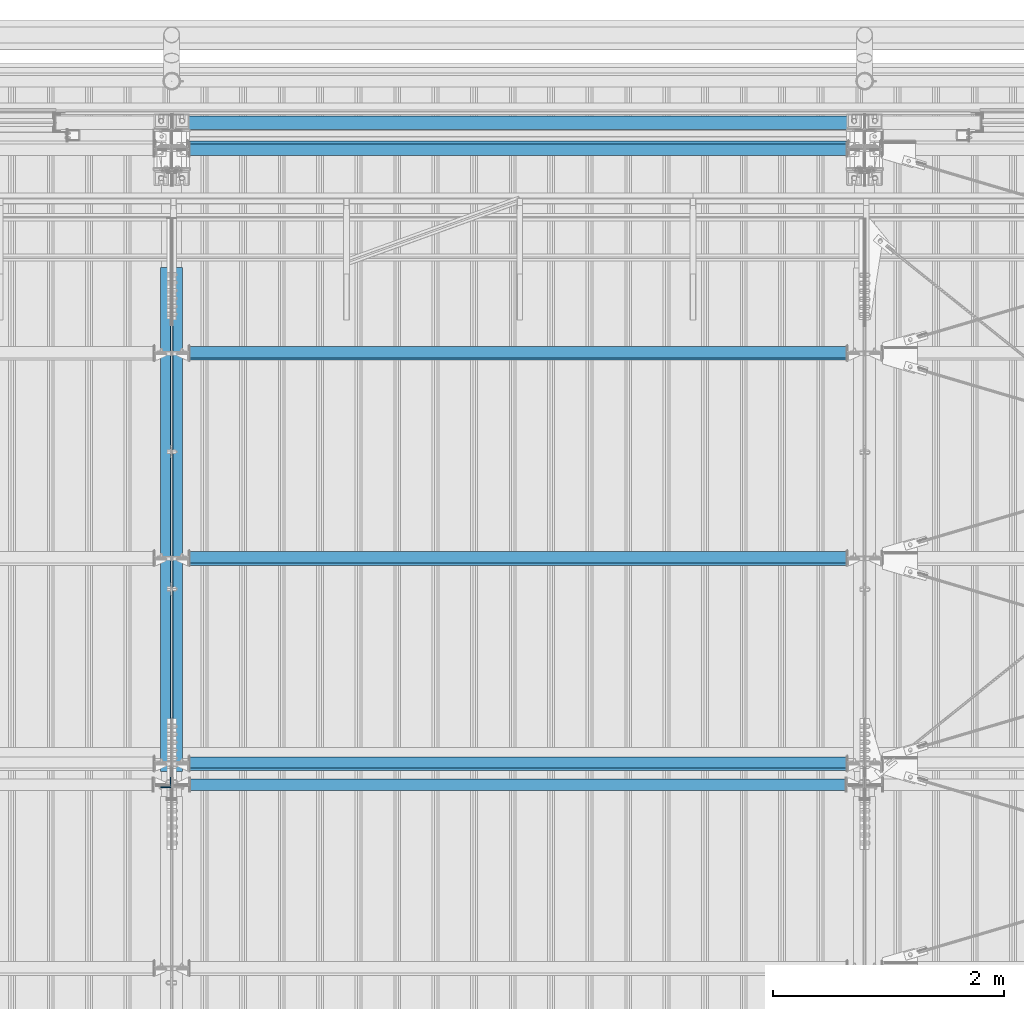
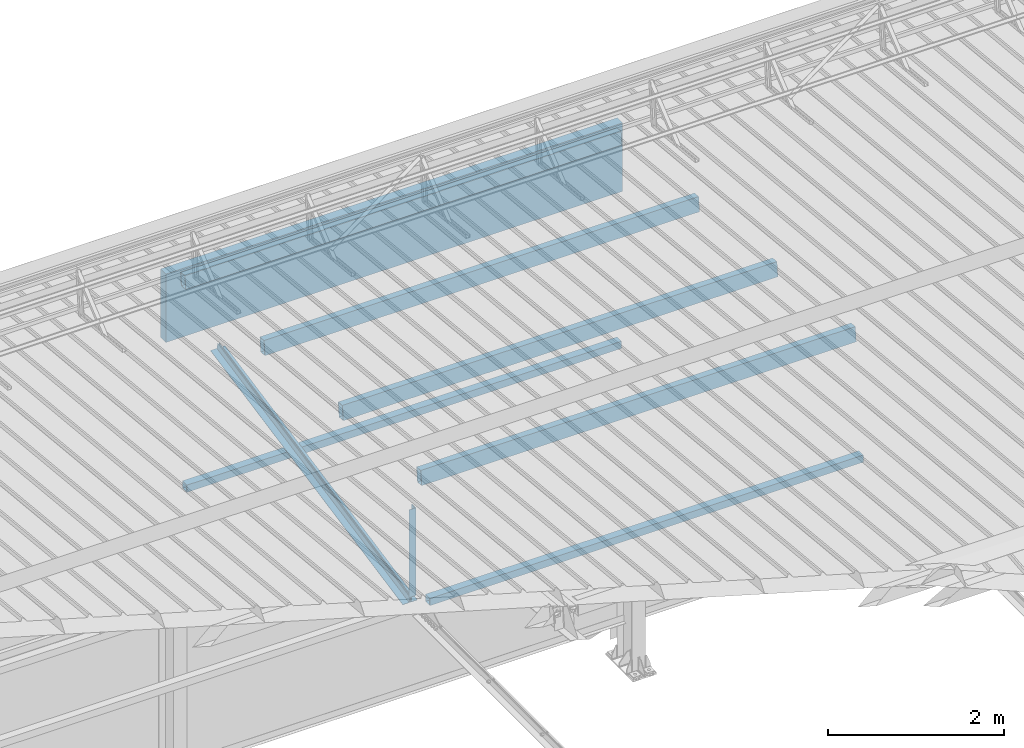
# One storey, part 285 of 709: 10 beams, 10 elements without a shape of their own.
"""IFC4 building model written with IfcOpenShell, lengths in millimetres."""

import ifcopenshell
import ifcopenshell.guid

model = None  # the IFC model being written
_history = None  # IfcOwnerHistory: only IFC2X3 demands one
_inside = {}  # id of a spatial element -> (the spatial element, [elements in it])
_under = {}  # id of a project, library or spatial element -> (it, [spatial elements below it])
_declared = {}  # id of a project -> (the project, [libraries it declares])
_typed = {}  # id of a type object -> (the type object, [elements of that type])
_made_of = {}  # id of a material, layer set ... -> (it, [elements and type objects made of it])


def new_model(schema):
    """Start an empty IFC model of exactly this schema.

    Asked for "IFC4X3", IfcOpenShell would pick the latest addendum, in which some entities
    have other attributes; the version numbers below select the first issue.
    IFC2X3 requires an IfcOwnerHistory on every rooted entity: one is made here for all.
    """
    global model, _history
    if schema == "IFC4X3":
        model = ifcopenshell.file(schema_version=(4, 3, 0, 0))
    else:
        model = ifcopenshell.file(schema=schema)
    _inside.clear()
    _under.clear()
    _declared.clear()
    _typed.clear()
    _made_of.clear()
    _history = None
    if model.schema == "IFC2X3":
        org = make("IfcOrganization", Name="unknown")
        user = make(
            "IfcPersonAndOrganization",
            ThePerson=make("IfcPerson", FamilyName="unknown"),
            TheOrganization=org,
        )
        app = make(
            "IfcApplication",
            ApplicationDeveloper=org,
            Version="unknown",
            ApplicationFullName="unknown",
            ApplicationIdentifier="unknown",
        )
        _history = make(
            "IfcOwnerHistory",
            OwningUser=user,
            OwningApplication=app,
            ChangeAction="ADDED",
            CreationDate=0,
        )
    return model


def make(cls, **values):
    """One entity of the class cls with the attributes given. An attribute that is None is left unset."""
    return model.create_entity(
        cls, **{name: value for name, value in values.items() if value is not None}
    )


def rooted(cls, **values):
    """An entity with a GlobalId (a new one), such as an element, a storey or a relation."""
    return make(cls, GlobalId=ifcopenshell.guid.new(), OwnerHistory=_history, **values)


def si_unit(unit_type, name, prefix=None):
    """IfcSIUnit, for example si_unit("LENGTHUNIT", "METRE", prefix="MILLI")."""
    return make("IfcSIUnit", UnitType=unit_type, Prefix=prefix, Name=name)


def assignment(units):
    """IfcUnitAssignment: the units of a project."""
    return None if units is None else make("IfcUnitAssignment", Units=units)


def point(xyz):
    """IfcCartesianPoint."""
    return None if xyz is None else make("IfcCartesianPoint", Coordinates=xyz)


def direction(xyz):
    """IfcDirection."""
    return None if xyz is None else make("IfcDirection", DirectionRatios=xyz)


def frame(location, z_axis=None, x_axis=None):
    """IfcAxis2Placement3D, a coordinate frame: its origin and axes. An axis left out is left unset."""
    return make(
        "IfcAxis2Placement3D",
        Location=point(location),
        Axis=direction(z_axis),
        RefDirection=direction(x_axis),
    )


def origin_with_axes():
    """The frame at (0, 0, 0) with the z axis (0, 0, 1) and the x axis (1, 0, 0) written out."""
    return frame((0.0, 0.0, 0.0), z_axis=(0.0, 0.0, 1.0), x_axis=(1.0, 0.0, 0.0))


def place(relative_to, where):
    """IfcLocalPlacement: puts the frame where relative to a parent placement (None: the world)."""
    return make(
        "IfcLocalPlacement", PlacementRelTo=relative_to, RelativePlacement=where
    )


def context(
    kind, dimensions, precision=None, world=None, true_north=None, identifier=None
):
    """IfcGeometricRepresentationContext, for example the 3D "Model" context."""
    return make(
        "IfcGeometricRepresentationContext",
        ContextIdentifier=identifier,
        ContextType=kind,
        CoordinateSpaceDimension=dimensions,
        Precision=precision,
        WorldCoordinateSystem=world,
        TrueNorth=true_north,
    )


def subcontext(parent, identifier, kind, view, scale=None):
    """IfcGeometricRepresentationSubContext, for example "Body" below "Model"."""
    return make(
        "IfcGeometricRepresentationSubContext",
        ContextIdentifier=identifier,
        ContextType=kind,
        ParentContext=parent,
        TargetScale=scale,
        TargetView=view,
    )


def project(units=None, contexts=None):
    """IfcProject with its units and contexts."""
    return rooted(
        "IfcProject",
        Name="project",
        RepresentationContexts=contexts,
        UnitsInContext=assignment(units),
    )


def spatial(cls, under=None, at=None, **own):
    """A site, building, storey or space (cls), placed at a placement, below another one or the project."""
    s = rooted(cls, ObjectPlacement=at, **own)
    if under is not None:
        _under.setdefault(under.id(), (under, []))[1].append(s)
    return s


def point_list(points):
    """IfcCartesianPointList2D or 3D."""
    cls = (
        "IfcCartesianPointList2D" if len(points[0]) == 2 else "IfcCartesianPointList3D"
    )
    return make(cls, CoordList=points)


def polygons(points, faces, closed=None, point_numbers=None):
    """IfcPolygonalFaceSet: a face is its outer loop, then its inner loops; points numbered from 1."""
    made = []
    for loops in faces:
        if len(loops) == 1:
            made.append(make("IfcIndexedPolygonalFace", CoordIndex=loops[0]))
        else:
            made.append(
                make(
                    "IfcIndexedPolygonalFaceWithVoids",
                    CoordIndex=loops[0],
                    InnerCoordIndices=loops[1:],
                )
            )
    return make(
        "IfcPolygonalFaceSet",
        Coordinates=point_list(points),
        Closed=closed,
        Faces=made,
        PnIndex=point_numbers,
    )


def shape(context_of_items, identifier, shape_type, items):
    """IfcShapeRepresentation: the items that make up one representation, for example the "Body"."""
    return make(
        "IfcShapeRepresentation",
        ContextOfItems=context_of_items,
        RepresentationIdentifier=identifier,
        RepresentationType=shape_type,
        Items=items,
    )


def material(Name=None, Category=None):
    """IfcMaterial."""
    return make("IfcMaterial", Name=Name, Category=Category)


def made_of(thing, what):
    """Note that an element or type object is made of a material, layer set ...; save() writes the relation."""
    if what is not None:
        _made_of.setdefault(what.id(), (what, []))[1].append(thing)
    return thing


def element(
    cls,
    number,
    at=None,
    inside=None,
    cuts=None,
    type_object=None,
    material=None,
    context=None,
    identifier="Body",
    shape_type=None,
    held_by="IfcProductDefinitionShape",
    body=None,
    shapes=None,
    **own,
):
    """One element of the class cls, such as IfcWall. Its Tag is "e" and its number.

    at: its placement. inside: the storey or other place that contains it. cuts: it is an
    opening in that element (IfcRelVoidsElement). A single representation is given by context,
    identifier, shape_type and body (its items); several are given by shapes. held_by: the class
    of the entity that holds the representations. save() writes the other relations.
    """
    e = rooted(cls, Tag="e%d" % number, ObjectPlacement=at, **own)
    if body is not None:
        shapes = [shape(context, identifier, shape_type, body)]
    if shapes is not None:
        e.Representation = make(held_by, Representations=shapes)
    if inside is not None:
        _inside.setdefault(inside.id(), (inside, []))[1].append(e)
    if cuts is not None:
        rooted(
            "IfcRelVoidsElement", RelatingBuildingElement=cuts, RelatedOpeningElement=e
        )
    if type_object is not None:
        _typed.setdefault(type_object.id(), (type_object, []))[1].append(e)
    return made_of(e, material)


def aggregate(whole, parts):
    """IfcRelAggregates: a whole, such as a stair, and the parts it consists of."""
    return rooted("IfcRelAggregates", RelatingObject=whole, RelatedObjects=parts)


def save(model, path):
    """Write the relations noted so far, then the file.

    IfcRelAggregates (storeys below a building ...), IfcRelContainedInSpatialStructure (elements
    in a storey), IfcRelDefinesByType, IfcRelAssociatesMaterial and IfcRelDeclares: one each for
    every whole, place, type object, material and project.
    """
    for whole, parts in _under.values():
        aggregate(whole, parts)
    for where, things in _inside.values():
        rooted(
            "IfcRelContainedInSpatialStructure",
            RelatedElements=things,
            RelatingStructure=where,
        )
    for kind, things in _typed.values():
        rooted("IfcRelDefinesByType", RelatedObjects=things, RelatingType=kind)
    for what, things in _made_of.values():
        rooted("IfcRelAssociatesMaterial", RelatedObjects=things, RelatingMaterial=what)
    for by, libraries in _declared.values():
        rooted("IfcRelDeclares", RelatingContext=by, RelatedDefinitions=libraries)
    model.write(path)


model = new_model("IFC4")

# Units and contexts
model_context = context("Model", 3, precision=0.2, world=origin_with_axes(), true_north=direction((0.0, 1.0)))
body_context = subcontext(model_context, "Body", "Model", "MODEL_VIEW")
ifc_project = project(units=[si_unit("LENGTHUNIT", "METRE", prefix="MILLI"), si_unit("AREAUNIT", "SQUARE_METRE"), si_unit("VOLUMEUNIT", "CUBIC_METRE"), si_unit("MASSUNIT", "GRAM", prefix="KILO"), si_unit("TIMEUNIT", "SECOND"), si_unit("PLANEANGLEUNIT", "RADIAN"), si_unit("SOLIDANGLEUNIT", "STERADIAN"), si_unit("THERMODYNAMICTEMPERATUREUNIT", "DEGREE_CELSIUS"), si_unit("LUMINOUSINTENSITYUNIT", "LUMEN")], contexts=[model_context])

# Site, building, storey
site_placement = place(None, origin_with_axes())
site = spatial("IfcSite", under=ifc_project, at=site_placement, CompositionType="ELEMENT")
building_placement = place(site_placement, origin_with_axes())
building = spatial("IfcBuilding", under=site, at=building_placement, Name="Undefined", CompositionType="ELEMENT")
storey_placement = place(building_placement, origin_with_axes())
storey = spatial("IfcBuildingStorey", under=building, at=storey_placement, Name="Undefined", CompositionType="ELEMENT", Elevation=0.0)

# Assembly, beam
assembly_1_placement = place(storey_placement, frame((34051.0, 21649.9404, 7109.99804), z_axis=(0.0, -0.1961161349, 0.9805806757), x_axis=(0.0, -0.9805806757, -0.1961161349)))
assembly_1 = element("IfcElementAssembly", 1, at=assembly_1_placement, inside=storey)
ifc_material_1 = material(Name="C345-5", Category="STEEL")
beam_1_placement = place(assembly_1_placement, origin_with_axes())
beam_1 = element("IfcBeam", 2, at=beam_1_placement, material=ifc_material_1, ObjectType="444", context=body_context, shape_type="Tessellation", body=[
    polygons([(868.11437, -45.0, -45.0), (868.11437, 45.0, -45.0), (5317.375, 45.0, -45.0), (5317.375, -45.0, -45.0), (868.11437, 45.0, -39.0), (5317.375, 45.0, -39.0), (868.11437, -39.0, -39.0), (5317.375, -39.0, -39.0), (868.11437, -39.0, 45.0), (5317.375, -39.0, 45.0), (868.11437, -45.0, 45.0), (5317.375, -45.0, 45.0)], [[[1, 2, 3, 4]], [[2, 5, 6, 3]], [[5, 7, 8, 6]], [[7, 9, 10, 8]], [[9, 11, 12, 10]], [[11, 1, 4, 12]], [[6, 8, 10, 12, 4, 3]], [[11, 9, 7, 5, 2, 1]]], closed=True),
])
aggregate(assembly_1, [beam_1])

assembly_2_placement = place(storey_placement, frame((33949.0, 16322.9404, 6044.59804), z_axis=(0.0, -0.1961161349, 0.9805806757), x_axis=(0.0, 0.9805806757, 0.1961161349)))
assembly_2 = element("IfcElementAssembly", 3, at=assembly_2_placement, inside=storey)
beam_2_placement = place(assembly_2_placement, origin_with_axes())
beam_2 = element("IfcBeam", 4, at=beam_2_placement, material=ifc_material_1, ObjectType="444", context=body_context, shape_type="Tessellation", body=[
    polygons([(115.12039, -45.0, -45.0), (115.12039, 45.0, -45.0), (4564.38102, 45.0, -45.0), (4564.38102, -45.0, -45.0), (115.12039, 45.0, -39.0), (4564.38102, 45.0, -39.0), (115.12039, -39.0, -39.0), (4564.38102, -39.0, -39.0), (115.12039, -39.0, 45.0), (4564.38102, -39.0, 45.0), (115.12039, -45.0, 45.0), (4564.38102, -45.0, 45.0)], [[[1, 2, 3, 4]], [[2, 5, 6, 3]], [[5, 7, 8, 6]], [[7, 9, 10, 8]], [[9, 11, 12, 10]], [[11, 1, 4, 12]], [[6, 8, 10, 12, 4, 3]], [[11, 9, 7, 5, 2, 1]]], closed=True),
])
aggregate(assembly_2, [beam_2])

assembly_3_placement = place(storey_placement, frame((33949.0, 16347.7, 7622.40002), z_axis=(0.0, 1.0, 0.0), x_axis=(0.0, 0.0, -1.0)))
assembly_3 = element("IfcElementAssembly", 5, at=assembly_3_placement, inside=storey)
beam_3_placement = place(assembly_3_placement, origin_with_axes())
beam_3 = element("IfcBeam", 6, at=beam_3_placement, material=ifc_material_1, ObjectType="436", context=body_context, shape_type="Tessellation", body=[
    polygons([(198.6891, -45.0, -45.0), (198.6891, 45.0, -45.0), (1412.4, 45.0, -45.0), (1412.4, -45.0, -45.0), (198.6891, 45.0, -39.0), (1412.4, 45.0, -39.0), (198.6891, -39.0, -39.0), (1412.4, -39.0, -39.0), (198.6891, -39.0, 45.0), (1412.4, -39.0, 45.0), (198.6891, -45.0, 45.0), (1412.4, -45.0, 45.0)], [[[1, 2, 3, 4]], [[2, 5, 6, 3]], [[5, 7, 8, 6]], [[7, 9, 10, 8]], [[9, 11, 12, 10]], [[11, 1, 4, 12]], [[6, 8, 10, 12, 4, 3]], [[11, 9, 7, 5, 2, 1]]], closed=True),
])
aggregate(assembly_3, [beam_3])

assembly_4_placement = place(storey_placement, frame((40000.0, 21827.0, 4310.0), z_axis=(0.0, 0.0, -1.0), x_axis=(-1.0, 0.0, 0.0)))
assembly_4 = element("IfcElementAssembly", 7, at=assembly_4_placement, inside=storey)
ifc_material_2 = material(Name="C355", Category="STEEL")
beam_4_placement = place(assembly_4_placement, origin_with_axes())
beam_4 = element("IfcBeam", 8, at=beam_4_placement, material=ifc_material_2, ObjectType="546", context=body_context, shape_type="Tessellation", body=[
    polygons([(155.0, -47.0, -47.0), (155.0, -47.0, 47.0), (5845.0, -47.0, 47.0), (5845.0, -47.0, -47.0), (155.0, 47.0, 47.0), (5845.0, 47.0, 47.0), (155.0, 47.0, -47.0), (5845.0, 47.0, -47.0), (155.0, -50.0, -50.0), (155.0, 50.0, -50.0), (5845.0, 50.0, -50.0), (5845.0, -50.0, -50.0), (155.0, 50.0, 50.0), (5845.0, 50.0, 50.0), (155.0, -50.0, 50.0), (5845.0, -50.0, 50.0)], [[[1, 2, 3, 4]], [[2, 5, 6, 3]], [[5, 7, 8, 6]], [[7, 1, 4, 8]], [[9, 10, 11, 12]], [[10, 13, 14, 11]], [[13, 15, 16, 14]], [[15, 9, 12, 16]], [[14, 16, 12, 11], [6, 8, 4, 3]], [[15, 13, 10, 9], [7, 5, 2, 1]]], closed=True),
])
aggregate(assembly_4, [beam_4])

assembly_5_placement = place(storey_placement, frame((34000.0, 16327.0, 6074.30002), z_axis=(0.0, -1.0, 0.0), x_axis=(1.0, 0.0, 0.0)))
assembly_5 = element("IfcElementAssembly", 9, at=assembly_5_placement, inside=storey)
beam_5_placement = place(assembly_5_placement, origin_with_axes())
beam_5 = element("IfcBeam", 10, at=beam_5_placement, material=ifc_material_2, ObjectType="557", context=body_context, shape_type="Tessellation", body=[
    polygons([(162.0, -47.0, -47.0), (162.0, -47.0, 47.0), (5838.0, -47.0, 47.0), (5838.0, -47.0, -47.0), (162.0, 47.0, 47.0), (5838.0, 47.0, 47.0), (162.0, 47.0, -47.0), (5838.0, 47.0, -47.0), (162.0, -50.0, -50.0), (162.0, 50.0, -50.0), (5838.0, 50.0, -50.0), (5838.0, -50.0, -50.0), (162.0, 50.0, 50.0), (5838.0, 50.0, 50.0), (162.0, -50.0, 50.0), (5838.0, -50.0, 50.0)], [[[1, 2, 3, 4]], [[2, 5, 6, 3]], [[5, 7, 8, 6]], [[7, 1, 4, 8]], [[9, 10, 11, 12]], [[10, 13, 14, 11]], [[13, 15, 16, 14]], [[15, 9, 12, 16]], [[14, 16, 12, 11], [6, 8, 4, 3]], [[15, 13, 10, 9], [7, 5, 2, 1]]], closed=True),
])
aggregate(assembly_5, [beam_5])

assembly_6_placement = place(storey_placement, frame((40000.0, 16509.95037, 7677.46908), z_axis=(0.0, -0.9950371902, 0.099503719), x_axis=(-1.0, 0.0, 0.0)))
assembly_6 = element("IfcElementAssembly", 11, at=assembly_6_placement, inside=storey)
beam_6_placement = place(assembly_6_placement, origin_with_axes())
beam_6 = element("IfcBeam", 12, at=beam_6_placement, material=ifc_material_2, ObjectType="579", context=body_context, shape_type="Tessellation", body=[
    polygons([(155.0, -96.0, -46.0), (155.0, -96.0, 46.0), (5845.0, -96.0, 46.0), (5845.0, -96.0, -46.0), (155.0, 96.0, 46.0), (5845.0, 96.0, 46.0), (155.0, 96.0, -46.0), (5845.0, 96.0, -46.0), (155.0, -100.0, -50.0), (155.0, 100.0, -50.0), (5845.0, 100.0, -50.0), (5845.0, -100.0, -50.0), (155.0, 100.0, 50.0), (5845.0, 100.0, 50.0), (155.0, -100.0, 50.0), (5845.0, -100.0, 50.0)], [[[1, 2, 3, 4]], [[2, 5, 6, 3]], [[5, 7, 8, 6]], [[7, 1, 4, 8]], [[9, 10, 11, 12]], [[10, 13, 14, 11]], [[13, 15, 16, 14]], [[15, 9, 12, 16]], [[14, 16, 12, 11], [6, 8, 4, 3]], [[15, 13, 10, 9], [7, 5, 2, 1]]], closed=True),
])
aggregate(assembly_6, [beam_6])

assembly_7_placement = place(storey_placement, frame((40000.0, 18286.65012, 7499.7991), z_axis=(0.0, -0.9950371902, 0.099503719), x_axis=(-1.0, 0.0, 0.0)))
assembly_7 = element("IfcElementAssembly", 13, at=assembly_7_placement, inside=storey)
beam_7_placement = place(assembly_7_placement, origin_with_axes())
beam_7 = element("IfcBeam", 14, at=beam_7_placement, material=ifc_material_2, ObjectType="579", context=body_context, shape_type="Tessellation", body=[
    polygons([(155.0, -96.0, -46.0), (155.0, -96.0, 46.0), (5845.0, -96.0, 46.0), (5845.0, -96.0, -46.0), (155.0, 96.0, 46.0), (5845.0, 96.0, 46.0), (155.0, 96.0, -46.0), (5845.0, 96.0, -46.0), (155.0, -100.0, -50.0), (155.0, 100.0, -50.0), (5845.0, 100.0, -50.0), (5845.0, -100.0, -50.0), (155.0, 100.0, 50.0), (5845.0, 100.0, 50.0), (155.0, -100.0, 50.0), (5845.0, -100.0, 50.0)], [[[1, 2, 3, 4]], [[2, 5, 6, 3]], [[5, 7, 8, 6]], [[7, 1, 4, 8]], [[9, 10, 11, 12]], [[10, 13, 14, 11]], [[13, 15, 16, 14]], [[15, 9, 12, 16]], [[14, 16, 12, 11], [6, 8, 4, 3]], [[15, 13, 10, 9], [7, 5, 2, 1]]], closed=True),
])
aggregate(assembly_7, [beam_7])

assembly_8_placement = place(storey_placement, frame((40000.0, 20063.34988, 7322.12913), z_axis=(0.0, -0.9950371902, 0.099503719), x_axis=(-1.0, 0.0, 0.0)))
assembly_8 = element("IfcElementAssembly", 15, at=assembly_8_placement, inside=storey)
beam_8_placement = place(assembly_8_placement, origin_with_axes())
beam_8 = element("IfcBeam", 16, at=beam_8_placement, material=ifc_material_2, ObjectType="579", context=body_context, shape_type="Tessellation", body=[
    polygons([(155.0, -96.0, -46.0), (155.0, -96.0, 46.0), (5845.0, -96.0, 46.0), (5845.0, -96.0, -46.0), (155.0, 96.0, 46.0), (5845.0, 96.0, 46.0), (155.0, 96.0, -46.0), (5845.0, 96.0, -46.0), (155.0, -100.0, -50.0), (155.0, 100.0, -50.0), (5845.0, 100.0, -50.0), (5845.0, -100.0, -50.0), (155.0, 100.0, 50.0), (5845.0, 100.0, 50.0), (155.0, -100.0, 50.0), (5845.0, -100.0, 50.0)], [[[1, 2, 3, 4]], [[2, 5, 6, 3]], [[5, 7, 8, 6]], [[7, 1, 4, 8]], [[9, 10, 11, 12]], [[10, 13, 14, 11]], [[13, 15, 16, 14]], [[15, 9, 12, 16]], [[14, 16, 12, 11], [6, 8, 4, 3]], [[15, 13, 10, 9], [7, 5, 2, 1]]], closed=True),
])
aggregate(assembly_8, [beam_8])

assembly_9_placement = place(storey_placement, frame((40000.0, 21841.04467, 7154.40952), z_axis=(0.0, -0.9950371902, 0.099503719), x_axis=(-1.0, 0.0, 0.0)))
assembly_9 = element("IfcElementAssembly", 17, at=assembly_9_placement, inside=storey)
beam_9_placement = place(assembly_9_placement, origin_with_axes())
beam_9 = element("IfcBeam", 18, at=beam_9_placement, material=ifc_material_2, ObjectType="578", context=body_context, shape_type="Tessellation", body=[
    polygons([(145.0, -86.0, -46.0), (145.0, -86.0, 46.0), (5855.0, -86.0, 46.0), (5855.0, -86.0, -46.0), (145.0, 86.0, 46.0), (5855.0, 86.0, 46.0), (145.0, 86.0, -46.0), (5855.0, 86.0, -46.0), (145.0, -90.0, -50.0), (145.0, 90.0, -50.0), (5855.0, 90.0, -50.0), (5855.0, -90.0, -50.0), (145.0, 90.0, 50.0), (5855.0, 90.0, 50.0), (145.0, -90.0, 50.0), (5855.0, -90.0, 50.0)], [[[1, 2, 3, 4]], [[2, 5, 6, 3]], [[5, 7, 8, 6]], [[7, 1, 4, 8]], [[9, 10, 11, 12]], [[10, 13, 14, 11]], [[13, 15, 16, 14]], [[15, 9, 12, 16]], [[14, 16, 12, 11], [6, 8, 4, 3]], [[15, 13, 10, 9], [7, 5, 2, 1]]], closed=True),
])
aggregate(assembly_9, [beam_9])

assembly_10_placement = place(storey_placement, frame((34010.0, 22060.0, 6845.0), z_axis=(0.0, 0.0, -1.0), x_axis=(1.0, 0.0, 0.0)))
assembly_10 = element("IfcElementAssembly", 19, at=assembly_10_placement, inside=storey)
ifc_material_3 = material(Name="Insulation", Category="Insulation")
beam_10_placement = place(assembly_10_placement, origin_with_axes())
beam_10 = element("IfcBeam", 20, at=beam_10_placement, material=ifc_material_3, ObjectType="P-108", context=body_context, shape_type="Tessellation", body=[
    polygons([(0.0, 60.0, 595.0), (0.0, -60.0, 595.0), (5980.0, -60.0, 595.0), (5980.0, 60.0, 595.0), (5980.0, 60.0, -351.923), (0.0, 60.0, -351.923), (0.0, -60.0, -351.923), (5980.0, -60.0, -351.923)], [[[1, 2, 3, 4]], [[1, 4, 5, 6]], [[2, 1, 6, 7]], [[3, 2, 7, 8]], [[4, 3, 8, 5]], [[7, 6, 5, 8]]], closed=True),
])
aggregate(assembly_10, [beam_10])

save(model, "model.ifc")
